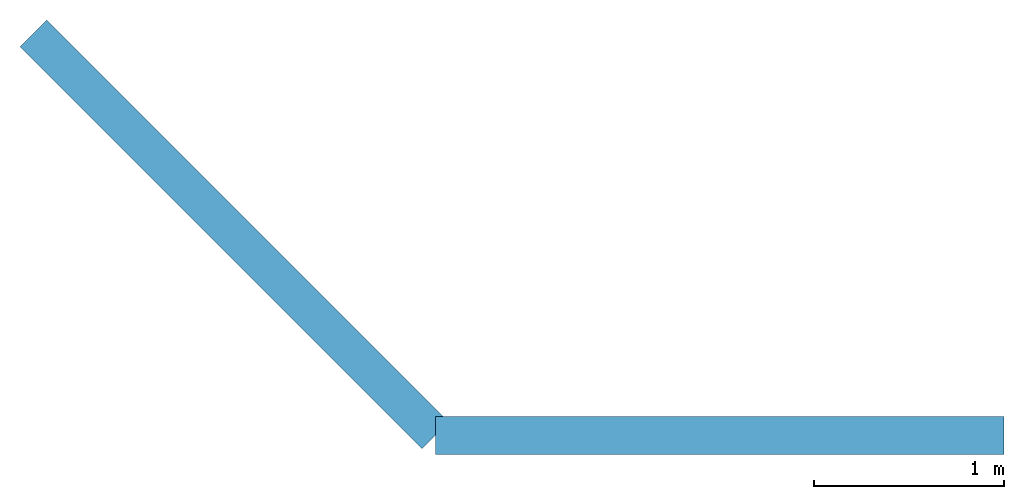
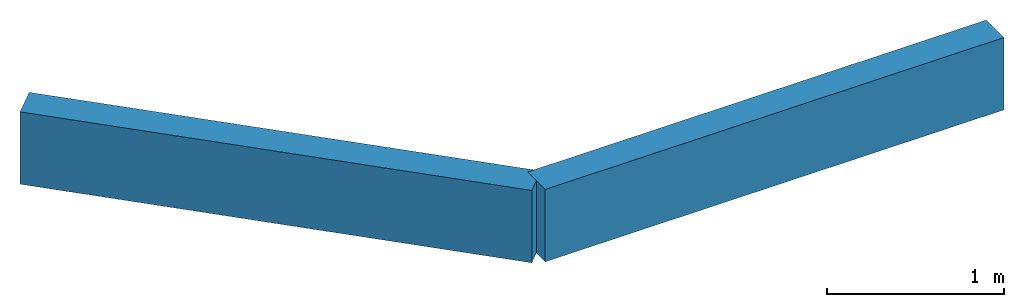
# Not in any storey: 2 beams.
"""IFC4 model written with IfcOpenShell, lengths in metres."""

from ifc_helpers import new_model, entity, si_unit, converted_unit, frame, origin_with_axes, origin_2d_with_axis, place, context, subcontext, project, rectangle, extrude, material, material_profile, profile_set, profile_usage, type_object, element, save


model = new_model("IFC4")

# Units and contexts
model_context = context("Model", 3, precision=1e-05, world=origin_with_axes())
plan_context = context("Plan", 2, precision=1e-05, world=origin_2d_with_axis())
body_context = subcontext(model_context, "Body", "Model", "MODEL_VIEW")
ifc_project = project(units=[si_unit("VOLUMEUNIT", "CUBIC_METRE"), si_unit("LENGTHUNIT", "METRE"), converted_unit("PLANEANGLEUNIT", "degree", entity("IfcReal", 0.0174532925199433), si_unit("PLANEANGLEUNIT", "RADIAN"), dimensions=[0, 0, 0, 0, 0, 0, 0]), si_unit("AREAUNIT", "SQUARE_METRE")], contexts=[model_context, plan_context])

# Beams
ifc_material = material()
ifc_material_profile_1 = material_profile(ifc_material, rectangle(XDim=0.200000002980232, YDim=0.5))
ifc_material_profile_2 = material_profile(ifc_material, rectangle(XDim=0.200000002980232, YDim=0.400000005960464))
ifc_profile_set = profile_set([ifc_material_profile_1, ifc_material_profile_2])
ifc_profile_usage_1 = profile_usage(ifc_profile_set, cardinal=5)
beam_type = type_object("IfcBeamType", PredefinedType="BEAM", material=ifc_profile_set)
beam_1_placement = place(None, frame((5.25, -0.249999701976776, 5.49999952316284), z_axis=(1.0, -7.54979012640433e-08, 7.54979012640433e-08), x_axis=(7.54979012640433e-08, 1.0, 7.16093850883226e-15)))
element("IfcBeam", 1, at=beam_1_placement, type_object=beam_type, material=ifc_profile_usage_1, Name="Beam", PredefinedType="NOTDEFINED", context=body_context, shape_type="SweptSolid", body=[
    extrude(rectangle(XDim=0.200000002980232, YDim=0.5), origin_with_axes(), (0.0, 0.0, 1.0), 3.00000000000001),
])
ifc_profile_usage_2 = profile_usage(ifc_profile_set, cardinal=5)
beam_2_placement = place(None, frame((5.25, -0.249999701976776, 5.49999952316284), z_axis=(-0.70710688829422, 0.707106649875641, 7.54979012640433e-08), x_axis=(-0.707106649875641, -0.70710688829422, 7.16093850883226e-15)))
element("IfcBeam", 2, at=beam_2_placement, type_object=beam_type, material=ifc_profile_usage_2, Name="Beam", PredefinedType="NOTDEFINED", context=body_context, shape_type="SweptSolid", body=[
    extrude(rectangle(XDim=0.200000002980232, YDim=0.5), origin_with_axes(), (0.0, 0.0, 1.0), 2.99999968210854),
])

save(model, "model.ifc")
